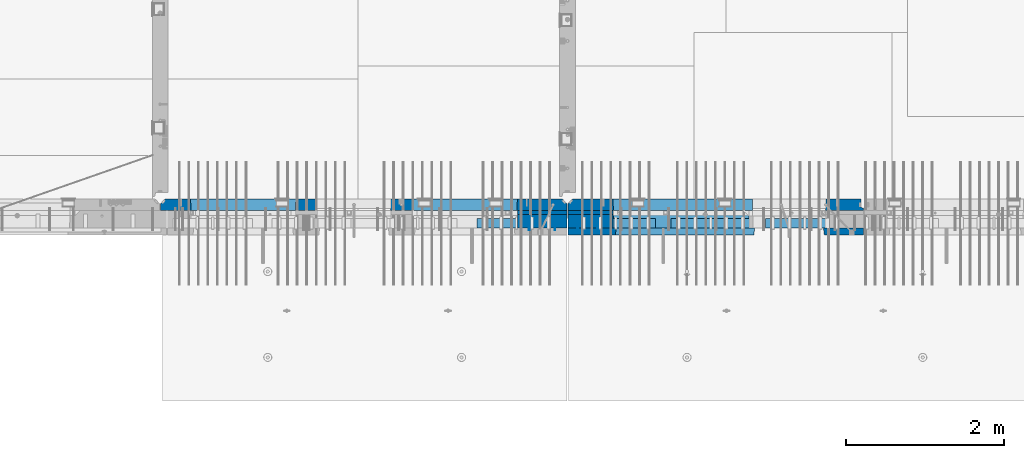
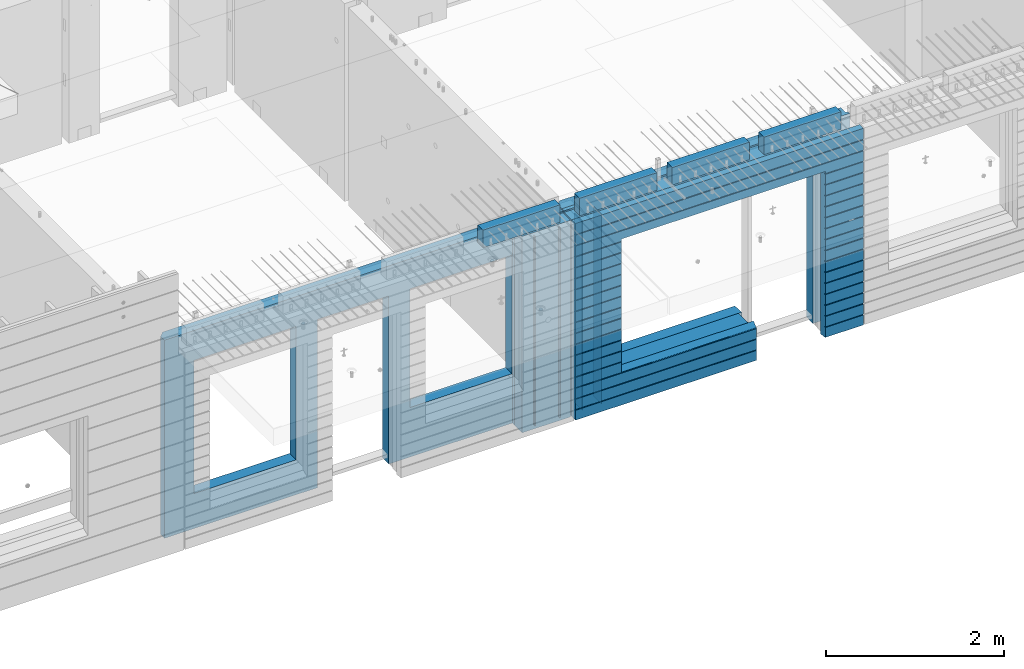
# One storey, part 197 of 309: 16 walls, 8 elements without a shape of their own.
"""IFC2X3 building model written with IfcOpenShell, lengths in millimetres."""

from ifc_helpers import new_model, si_unit, frame, origin_with_axes, place, context, subcontext, project, spatial, faceted_brep, material, type_object, element, aggregate, save


model = new_model("IFC2X3")

# Units and contexts
model_context = context("Model", 3, precision=1e-05, world=origin_with_axes())
body_context = subcontext(model_context, "Body", "Model", "MODEL_VIEW")
ifc_project = project(units=[si_unit("LENGTHUNIT", "METRE", prefix="MILLI"), si_unit("AREAUNIT", "SQUARE_METRE"), si_unit("VOLUMEUNIT", "CUBIC_METRE"), si_unit("MASSUNIT", "GRAM", prefix="KILO"), si_unit("TIMEUNIT", "SECOND"), si_unit("PLANEANGLEUNIT", "RADIAN"), si_unit("SOLIDANGLEUNIT", "STERADIAN"), si_unit("THERMODYNAMICTEMPERATUREUNIT", "DEGREE_CELSIUS"), si_unit("LUMINOUSINTENSITYUNIT", "LUMEN")], contexts=[model_context])

# Site, building, storey
site_placement = place(None, origin_with_axes())
site = spatial("IfcSite", under=ifc_project, at=site_placement, CompositionType="ELEMENT")
building_placement = place(site_placement, origin_with_axes())
building = spatial("IfcBuilding", under=site, at=building_placement, CompositionType="ELEMENT")
storey_placement = place(building_placement, origin_with_axes())
storey = spatial("IfcBuildingStorey", under=building, at=storey_placement, Name="7", CompositionType="ELEMENT", Elevation=0.0)

# Assembly, walls
assembly_1_placement = place(storey_placement, origin_with_axes())
assembly_1 = element("IfcElementAssembly", 1, at=assembly_1_placement, inside=storey, AssemblyPlace="NOTDEFINED", PredefinedType="REINFORCEMENT_UNIT")
ifc_material_1 = material(Name="Undefined")
wall_type_1 = type_object("IfcWallType", PredefinedType="NOTDEFINED")
wall_1_placement = place(assembly_1_placement, frame((21325.0, 7780.0, 101115.0), z_axis=(0.0, 0.0, 1.0), x_axis=(0.0, -1.0, 0.0)))
wall_1 = element("IfcWall", 2, at=wall_1_placement, type_object=wall_type_1, material=ifc_material_1, Name="(PD)", context=body_context, shape_type="Brep", body=[
    faceted_brep([(0.0, 5.0, -1300.0), (0.0, 5.0, 1300.0), (180.0, 5.0, 1300.0), (180.0, 5.0, -1300.0), (0.0, -5.0, 1300.0), (180.0, -5.0, 1300.0), (0.0, -5.0, -1300.0), (180.0, -5.0, -1300.0)], [[[0, 1, 2, 3]], [[1, 4, 5, 2]], [[4, 6, 7, 5]], [[6, 0, 3, 7]], [[5, 7, 3, 2]], [[6, 4, 1, 0]]]),
])
wall_2_placement = place(assembly_1_placement, frame((21650.0, 7780.0, 101115.0), z_axis=(0.0, 0.0, 1.0), x_axis=(0.0, -1.0, 0.0)))
wall_2 = element("IfcWall", 3, at=wall_2_placement, type_object=wall_type_1, material=ifc_material_1, Name="(PD)", context=body_context, shape_type="Brep", body=[
    faceted_brep([(0.0, 5.0, -1300.0), (0.0, 5.0, 1300.0), (180.0, 5.0, 1300.0), (180.0, 5.0, -1300.0), (0.0, -5.0, 1300.0), (180.0, -5.0, 1300.0), (0.0, -5.0, -1300.0), (180.0, -5.0, -1300.0)], [[[0, 1, 2, 3]], [[1, 4, 5, 2]], [[4, 6, 7, 5]], [[6, 0, 3, 7]], [[5, 7, 3, 2]], [[6, 4, 1, 0]]]),
])

assembly_2_placement = place(storey_placement, origin_with_axes())
assembly_2 = element("IfcElementAssembly", 4, at=assembly_2_placement, inside=storey, AssemblyPlace="NOTDEFINED", PredefinedType="REINFORCEMENT_UNIT")
wall_3_placement = place(assembly_2_placement, frame((22190.0, 7780.0, 101115.0), z_axis=(0.0, 0.0, 1.0), x_axis=(0.0, -1.0, 0.0)))
wall_3 = element("IfcWall", 5, at=wall_3_placement, type_object=wall_type_1, material=ifc_material_1, Name="(PD)", context=body_context, shape_type="Brep", body=[
    faceted_brep([(0.0, 5.0, -1300.0), (0.0, 5.0, 1300.0), (180.0, 5.0, 1300.0), (180.0, 5.0, -1300.0), (0.0, -5.0, 1300.0), (180.0, -5.0, 1300.0), (0.0, -5.0, -1300.0), (180.0, -5.0, -1300.0)], [[[0, 1, 2, 3]], [[1, 4, 5, 2]], [[4, 6, 7, 5]], [[6, 0, 3, 7]], [[5, 7, 3, 2]], [[6, 4, 1, 0]]]),
])
wall_4_placement = place(assembly_2_placement, frame((21940.0, 7780.0, 101115.0), z_axis=(0.0, 0.0, 1.0), x_axis=(0.0, -1.0, 0.0)))
wall_4 = element("IfcWall", 6, at=wall_4_placement, type_object=wall_type_1, material=ifc_material_1, Name="(PD)", context=body_context, shape_type="Brep", body=[
    faceted_brep([(0.0, 5.0, -1300.0), (0.0, 5.0, 1300.0), (180.0, 5.0, 1300.0), (180.0, 5.0, -1300.0), (0.0, -5.0, 1300.0), (180.0, -5.0, 1300.0), (0.0, -5.0, -1300.0), (180.0, -5.0, -1300.0)], [[[0, 1, 2, 3]], [[1, 4, 5, 2]], [[4, 6, 7, 5]], [[6, 0, 3, 7]], [[5, 7, 3, 2]], [[6, 4, 1, 0]]]),
])

# Assemblies, walls
assembly_3_placement = place(storey_placement, origin_with_axes())
assembly_3 = element("IfcElementAssembly", 7, at=assembly_3_placement, inside=storey, AssemblyPlace="NOTDEFINED", PredefinedType="REINFORCEMENT_UNIT")
assembly_4_placement = place(assembly_3_placement, origin_with_axes())
assembly_4 = element("IfcElementAssembly", 8, at=assembly_4_placement, Name="Steel Assembly", AssemblyPlace="NOTDEFINED", PredefinedType="NOTDEFINED")
ifc_material_2 = material()
wall_type_2 = type_object("IfcWallType", PredefinedType="NOTDEFINED")
wall_5_placement = place(assembly_4_placement, frame((24309.9998568133, 7690.00021946163, 102590.0), z_axis=(0.0, 0.0, 1.0), x_axis=(1.0, 0.0, 0.0)))
wall_5 = element("IfcWall", 9, at=wall_5_placement, type_object=wall_type_2, material=ifc_material_2, context=body_context, shape_type="Brep", body=[
    faceted_brep([(0.0, 60.0, -120.0), (0.0, 60.0, 120.0), (1000.0, 60.0, 120.0), (1000.0, 60.0, -120.0), (0.0, -60.0, 120.0), (1000.0, -60.0, 120.0), (0.0, -60.0, -120.0), (1000.0, -60.0, -120.0)], [[[0, 1, 2, 3]], [[1, 4, 5, 2]], [[4, 6, 7, 5]], [[6, 0, 3, 7]], [[5, 7, 3, 2]], [[6, 4, 1, 0]]]),
])
aggregate(assembly_4, [wall_5])
assembly_5_placement = place(assembly_3_placement, origin_with_axes())
assembly_5 = element("IfcElementAssembly", 10, at=assembly_5_placement, Name="Steel Assembly", AssemblyPlace="NOTDEFINED", PredefinedType="NOTDEFINED")
wall_6_placement = place(assembly_5_placement, frame((23119.9998568133, 7690.00021946163, 102590.0), z_axis=(0.0, 0.0, 1.0), x_axis=(1.0, 0.0, 0.0)))
wall_6 = element("IfcWall", 11, at=wall_6_placement, type_object=wall_type_2, material=ifc_material_2, context=body_context, shape_type="Brep", body=[
    faceted_brep([(0.0, 60.0, -120.0), (0.0, 60.0, 120.0), (1000.0, 60.0, 120.0), (1000.0, 60.0, -120.0), (0.0, -60.0, 120.0), (1000.0, -60.0, 120.0), (0.0, -60.0, -120.0), (1000.0, -60.0, -120.0)], [[[0, 1, 2, 3]], [[1, 4, 5, 2]], [[4, 6, 7, 5]], [[6, 0, 3, 7]], [[5, 7, 3, 2]], [[6, 4, 1, 0]]]),
])
aggregate(assembly_5, [wall_6])
assembly_6_placement = place(assembly_3_placement, origin_with_axes())
assembly_6 = element("IfcElementAssembly", 12, at=assembly_6_placement, Name="Steel Assembly", AssemblyPlace="NOTDEFINED", PredefinedType="NOTDEFINED")
aggregate(assembly_3, [assembly_4, assembly_5, assembly_6])
wall_7_placement = place(assembly_6_placement, frame((21919.9998568133, 7690.00021946163, 102590.0), z_axis=(0.0, 0.0, 1.0), x_axis=(1.0, 0.0, 0.0)))
wall_7 = element("IfcWall", 13, at=wall_7_placement, type_object=wall_type_2, material=ifc_material_2, context=body_context, shape_type="Brep", body=[
    faceted_brep([(0.0, 60.0, -120.0), (0.0, 60.0, 120.0), (1000.0, 60.0, 120.0), (1000.0, 60.0, -120.0), (0.0, -60.0, 120.0), (1000.0, -60.0, 120.0), (0.0, -60.0, -120.0), (1000.0, -60.0, -120.0)], [[[0, 1, 2, 3]], [[1, 4, 5, 2]], [[4, 6, 7, 5]], [[6, 0, 3, 7]], [[5, 7, 3, 2]], [[6, 4, 1, 0]]]),
])
aggregate(assembly_6, [wall_7])

# Assemblies, wall
assembly_7_placement = place(storey_placement, origin_with_axes())
assembly_7 = element("IfcElementAssembly", 14, at=assembly_7_placement, inside=storey, AssemblyPlace="NOTDEFINED", PredefinedType="REINFORCEMENT_UNIT")
assembly_8_placement = place(assembly_7_placement, origin_with_axes())
assembly_8 = element("IfcElementAssembly", 15, at=assembly_8_placement, Name="Steel Assembly", AssemblyPlace="NOTDEFINED", PredefinedType="NOTDEFINED")
aggregate(assembly_7, [assembly_8])
wall_8_placement = place(assembly_8_placement, frame((20664.9998568133, 7690.00021946163, 102590.0), z_axis=(0.0, 0.0, 1.0), x_axis=(1.0, 0.0, 0.0)))
wall_8 = element("IfcWall", 16, at=wall_8_placement, type_object=wall_type_2, material=ifc_material_2, context=body_context, shape_type="Brep", body=[
    faceted_brep([(0.0, 60.0, -120.0), (0.0, 60.0, 120.0), (1000.0, 60.0, 120.0), (1000.0, 60.0, -120.0), (0.0, -60.0, 120.0), (1000.0, -60.0, 120.0), (0.0, -60.0, -120.0), (1000.0, -60.0, -120.0)], [[[0, 1, 2, 3]], [[1, 4, 5, 2]], [[4, 6, 7, 5]], [[6, 0, 3, 7]], [[5, 7, 3, 2]], [[6, 4, 1, 0]]]),
])
aggregate(assembly_8, [wall_8])

# Wall
ifc_material_3 = material(Name="CONCRETE/C35/45")
wall_type_3 = type_object("IfcWallType", PredefinedType="NOTDEFINED")
wall_9_placement = place(assembly_1_placement, frame((21810.0, 7925.0, 101112.5), z_axis=(0.0, 0.0, 1.0), x_axis=(-1.0, 3.00000001838171e-08, 0.0)))
wall_9 = element("IfcWall", 17, at=wall_9_placement, type_object=wall_type_3, material=ifc_material_3, context=body_context, shape_type="Brep", body=[
    faceted_brep([(5145.0, 75.0, -1357.5), (5145.0, -15.0, -1357.5), (5085.0, -75.0, -1357.5), (3165.00051719707, -75.0, -1357.5), (3161.15436335092, 75.0, -1357.5), (5085.0, -75.0, 1357.5), (5145.0, -15.0, 1357.5), (5145.0, 75.0, 1357.5), (10.0, 75.0, 1357.5), (10.0, -15.0, 1357.5), (70.0, -75.0, 1357.5), (10.0, -15.0, -1357.5), (70.0, -75.0, -1357.5), (10.0, 75.0, -1357.5), (2238.84667104322, 75.0, -1357.5), (2235.00051719707, -75.0, -1357.5), (2238.84667104322, 75.0, 948.653846153844), (2235.00051719707, -75.0, 952.5), (635.00013572734, -75.0, -682.5), (639.054189781393, 75.0, -678.445945945947), (639.054189781393, 75.0, 948.445945945947), (635.00013572734, -75.0, 952.5), (1965.00013572734, -75.0, -682.5), (1960.94608167329, 75.0, -678.445945945947), (1965.00013572734, -75.0, 952.5), (1960.94608167329, 75.0, 948.445945945947), (4764.99937278789, -75.0, -882.5), (4760.94531873383, 75.0, -878.445945945947), (3439.05342684194, 75.0, -878.445945945947), (3434.99937278789, -75.0, -882.5), (3165.00051719707, -75.0, 952.5), (3434.99937278789, -75.0, 952.5), (4764.99937278789, -75.0, 952.5), (4760.94531873383, 75.0, 948.445945945947), (3439.05342684194, 75.0, 948.445945945947), (3161.15436335092, 75.0, 948.653846153844)], [[[0, 1, 2, 3, 4]], [[5, 2, 1, 6]], [[0, 7, 6, 1]], [[5, 6, 7, 8, 9, 10]], [[9, 11, 12, 10]], [[8, 13, 11, 9]], [[12, 11, 13, 14, 15]], [[15, 14, 16, 17]], [[18, 19, 20, 21]], [[22, 23, 19, 18]], [[23, 22, 24, 25]], [[21, 20, 25, 24]], [[26, 27, 28, 29]], [[3, 2, 5, 10, 12, 15, 17, 30], [26, 29, 31, 32], [22, 18, 21, 24]], [[27, 26, 32, 33]], [[31, 34, 33, 32]], [[29, 28, 34, 31]], [[13, 8, 7, 0, 4, 35, 16, 14], [27, 33, 34, 28], [23, 25, 20, 19]], [[17, 16, 35, 30]], [[4, 3, 30, 35]]]),
])

wall_10_placement = place(assembly_2_placement, frame((25550.0, 7925.0, 101112.5), z_axis=(0.0, 0.0, 1.0), x_axis=(-1.0, 3.00000001838171e-08, 0.0)))
wall_10 = element("IfcWall", 18, at=wall_10_placement, type_object=wall_type_3, material=ifc_material_3, context=body_context, shape_type="Brep", body=[
    faceted_brep([(0.0, 75.0, 1357.5), (0.0, 75.0, -1357.5), (0.0, 45.0, -1357.5), (0.0, 45.0, 1357.5), (475.000517197066, -75.0, -1357.5), (478.846671043222, 75.0, -1357.5), (478.846671043219, 75.0, 948.653846153844), (475.000517197066, -75.0, 952.5), (32.5, -75.0, -1357.5), (32.5, 32.0, -1357.5), (32.5, -75.0, 1357.5), (32.5, 32.0, 1357.5), (3675.0, -75.0, 1357.5), (3735.0, -15.0, 1357.5), (3735.0, 75.0, 1357.5), (3735.0, 75.0, -1357.5), (3735.0, -15.0, -1357.5), (3675.0, -75.0, -1357.5), (1405.00051719707, -75.0, -1357.5), (1401.15436335091, 75.0, -1357.5), (1405.00051719707, -75.0, -882.5), (1401.15436335091, 75.0, -878.445945945947), (1334.05403802673, 75.0, 948.653846153844), (3160.9460816706, 75.0, -878.445945945947), (3160.9460816706, 75.0, 948.445945945947), (1401.15436335091, 75.0, 948.653846153844), (1330.00013572465, -75.0, 952.5), (1405.00051719707, -75.0, 952.5), (3165.00013572465, -75.0, -882.5), (3165.00013572465, -75.0, 952.5)], [[[0, 1, 2, 3]], [[4, 5, 6, 7]], [[8, 9, 2, 1, 5, 4]], [[10, 11, 9, 8]], [[3, 2, 9, 11]], [[10, 12, 13, 14, 0, 3, 11]], [[15, 14, 13, 16]], [[12, 17, 16, 13]], [[15, 16, 17, 18, 19]], [[19, 18, 20, 21]], [[22, 6, 5, 1, 0, 14, 15, 19, 21, 23, 24, 25]], [[26, 7, 6, 22, 25, 27]], [[28, 20, 18, 17, 12, 10, 8, 4, 7, 26, 27, 29]], [[25, 24, 29, 27]], [[23, 28, 29, 24]], [[21, 20, 28, 23]]]),
])

wall_type_4 = type_object("IfcWallType", PredefinedType="NOTDEFINED")
wall_11_placement = place(assembly_1_placement, frame((21800.0000381475, 7825.0, 101112.5), z_axis=(0.0, 0.0, 1.0), x_axis=(-1.0, 3.00000001838171e-08, 0.0)))
wall_11 = element("IfcWall", 19, at=wall_11_placement, type_object=wall_type_4, material=ifc_material_3, context=body_context, shape_type="Brep", body=[
    faceted_brep([(0.0, 25.0, -1357.5), (0.0, 25.0, 1357.5), (625.001908754726, 25.0, 1357.5), (625.001908754726, 25.0, -1357.5), (0.0, -25.0, 1357.5), (625.001908754726, -25.0, 1357.5), (0.0, -25.0, -1357.5), (625.001908754726, -25.0, -1357.5)], [[[0, 1, 2, 3]], [[1, 4, 5, 2]], [[4, 6, 7, 5]], [[6, 0, 3, 7]], [[5, 7, 3, 2]], [[6, 4, 1, 0]]]),
])

wall_12_placement = place(assembly_2_placement, frame((22385.0000381475, 7825.00011629906, 101112.5), z_axis=(0.0, 0.0, 1.0), x_axis=(-1.0, 3.00000001838171e-08, 0.0)))
wall_12 = element("IfcWall", 20, at=wall_12_placement, type_object=wall_type_4, material=ifc_material_3, context=body_context, shape_type="Brep", body=[
    faceted_brep([(0.0, 25.0, -1357.5), (0.0, 25.0, 1357.5), (570.001908754726, 25.0, 1357.5), (570.001908754726, 25.0, -1357.5), (0.0, -25.0, 1357.5), (570.001908754726, -25.0, 1357.5), (0.0, -25.0, -1357.5), (570.001908754726, -25.0, -1357.5)], [[[0, 1, 2, 3]], [[1, 4, 5, 2]], [[4, 6, 7, 5]], [[6, 0, 3, 7]], [[5, 7, 3, 2]], [[6, 4, 1, 0]]]),
])

ifc_material_4 = material(Name="SPU")
wall_type_5 = type_object("IfcWallType", PredefinedType="NOTDEFINED")
wall_13_placement = place(assembly_1_placement, frame((21800.0000381475, 7715.0, 101102.5), z_axis=(0.0, 0.0, 1.0), x_axis=(-1.0, 3.00000001838171e-08, 0.0)))
wall_13 = element("IfcWall", 21, at=wall_13_placement, type_object=wall_type_5, material=ifc_material_4, context=body_context, shape_type="Brep", body=[
    faceted_brep([(0.0, 85.0, -1347.5), (0.0, 85.0, 1347.5), (625.001908754726, 85.0, 1347.5), (625.001908754726, 85.0, -1347.5), (0.0, -85.0, 1347.5), (625.001908754726, -85.0, 1347.5), (0.0, -85.0, -1347.5), (625.001908754726, -85.0, -1347.5)], [[[0, 1, 2, 3]], [[1, 4, 5, 2]], [[4, 6, 7, 5]], [[6, 0, 3, 7]], [[5, 7, 3, 2]], [[6, 4, 1, 0]]]),
])

aggregate(assembly_1, [wall_13, wall_11, wall_1, wall_2, wall_9])

wall_14_placement = place(assembly_2_placement, frame((22385.0000381475, 7715.00011629906, 101102.5), z_axis=(0.0, 0.0, 1.0), x_axis=(-1.0, 3.00000001838171e-08, 0.0)))
wall_14 = element("IfcWall", 22, at=wall_14_placement, type_object=wall_type_5, material=ifc_material_4, context=body_context, shape_type="Brep", body=[
    faceted_brep([(0.0, 85.0, -1347.5), (0.0, 85.0, 1347.5), (570.001908754726, 85.0, 1347.5), (570.001908754726, 85.0, -1347.5), (0.0, -85.0, 1347.5), (570.001908754726, -85.0, 1347.5), (0.0, -85.0, -1347.5), (570.001908754726, -85.0, -1347.5)], [[[0, 1, 2, 3]], [[1, 4, 5, 2]], [[4, 6, 7, 5]], [[6, 0, 3, 7]], [[5, 7, 3, 2]], [[6, 4, 1, 0]]]),
])

ifc_material_5 = material(Name="CONCRETE/C30/37")
wall_type_6 = type_object("IfcWallType", PredefinedType="NOTDEFINED")
wall_15_placement = place(assembly_2_placement, frame((25550.0, 7587.5, 101102.5), z_axis=(0.0, 0.0, 1.0), x_axis=(-1.0, 3.00000001838171e-08, 0.0)))
wall_15 = element("IfcWall", 23, at=wall_15_placement, type_object=wall_type_6, material=ifc_material_5, context=body_context, shape_type="Brep", body=[
    faceted_brep([(3135.00013572465, 42.5, -912.000000055254), (3135.00013572465, 42.5, -912.5), (3134.8486205936, 41.2121213860491, -911.742424344731), (3735.0, 32.4999991126861, -1049.99999959956), (3735.0, 32.4999992506973, -1060.00000000076), (1383.82179161871, 32.4999992506973, -1060.00000000076), (1383.82179160247, 32.4999991126861, -1049.99999959956), (3735.0, 42.5, -1062.00000005522), (1384.99845837354, 42.5, -1062.00000005522), (3735.0, 42.5, -1198.00000011075), (1384.99845837354, 42.5, -1198.00000011075), (3735.0, 32.4999991121604, -1199.99999959957), (1383.8217916024, 32.4999991121604, -1199.99999959957), (3735.0, 32.4999992501671, -1210.00000000079), (1383.82179161864, 32.4999992501671, -1210.00000000079), (3735.0, 42.5, -1212.00000005524), (1384.99845837354, 42.5, -1212.00000005524), (3735.0, 42.5, -1347.5), (1384.99845837354, 42.5, -1347.5), (3735.0, -42.5, -1347.5), (1374.99679170687, -42.5, -1347.5), (3.63797880709171e-12, 32.4999992499725, 1039.99999999921), (3735.0, 32.4999992499725, 1039.99999999921), (3735.0, 42.5, 1037.99999994476), (0.0, 42.5, 1037.99999994476), (3.63797880709171e-12, 32.4999991119639, 1050.00000040043), (3735.0, 32.4999991119639, 1050.00000040043), (0.0, 42.5, 1051.99999988925), (3735.0, 42.5, 1051.99999988925), (0.0, 42.5, 1187.99999994476), (3735.0, 42.5, 1187.99999994476), (-3.63797880709171e-12, 32.499999249967, 1189.99999999923), (3735.0, 32.499999249967, 1189.99999999923), (-3.63797880709171e-12, 32.4999991119576, 1200.00000040043), (3735.0, 32.4999991119576, 1200.00000040043), (0.0, 42.5, 1201.99999988925), (3735.0, 42.5, 1201.99999988925), (0.0, 42.5, 1347.5), (3735.0, 42.5, 1347.5), (0.0, -42.5, 1347.5), (3735.0, -42.5, 1347.5), (3125.00013572465, -42.5, 927.5), (3125.00013572465, -42.5, -862.5), (1374.99679170687, -42.5, -862.5), (0.0, -42.5, -1347.5), (505.000125040202, -42.5, -1347.5), (505.000125040206, -42.5, 927.5), (505.000125040206, -42.5, 932.502857142856), (1370.00013572465, -42.5, 932.502857142856), (1374.99679170687, -42.5, 932.5), (3125.00013572465, -42.5, 932.5), (0.0, 42.5, -1347.5), (494.998458373539, 42.5, -1347.5), (0.0, 42.5, -1212.00000005524), (494.998458373539, 42.5, -1212.00000005524), (0.0, 32.4999992501671, -1210.00000000079), (496.175125128437, 32.4999992501671, -1210.00000000079), (0.0, 32.4999991121604, -1199.99999959957), (496.175125144673, 32.4999991121604, -1199.99999959957), (0.0, 42.5, -1198.00000011075), (494.998458373539, 42.5, -1198.00000011075), (0.0, 42.5, -1062.00000005522), (494.998458373539, 42.5, -1062.00000005522), (0.0, 32.4999992506973, -1060.00000000076), (496.175125128375, 32.4999992506973, -1060.00000000076), (0.0, 32.4999991126861, -1049.99999959956), (496.175125144611, 32.4999991126861, -1049.99999959956), (0.0, 42.5, -1048.00000011074), (494.998458373539, 42.5, -1048.00000011074), (0.0, 42.5, -912.000000055254), (494.998458373539, 42.5, -912.000000055254), (0.0, 32.4999992512376, -910.000000000786), (496.175125128309, 32.4999992512376, -910.000000000786), (0.0, 32.499999113239, -899.99999959959), (496.175125144546, 32.499999113239, -899.99999959959), (0.0, 42.5, -898.000000110769), (494.998458373539, 42.5, -898.000000110769), (0.0, 42.5, -762.000000055225), (494.998458373539, 42.5, -762.000000055225), (0.0, 32.4999992517696, -760.000000000757), (496.175125128244, 32.4999992517696, -760.000000000757), (0.0, 32.4999991137702, -749.99999959956), (496.175125144484, 32.4999991137702, -749.99999959956), (0.0, 42.5, -748.00000011074), (494.998458373539, 42.5, -748.00000011074), (0.0, 42.5, -612.000000055239), (494.998458373539, 42.5, -612.000000055239), (0.0, 32.4999992522971, -610.000000000771), (496.175125128182, 32.4999992522971, -610.000000000771), (0.0, 32.4999991143004, -599.99999959956), (496.175125144422, 32.4999991143004, -599.99999959956), (0.0, 42.5, -598.000000110755), (494.998458373539, 42.5, -598.000000110755), (0.0, 42.5, -462.000000055239), (494.998458373539, 42.5, -462.000000055239), (0.0, 32.4999992528365, -460.000000000771), (496.17512512812, 32.4999992528365, -460.000000000771), (0.0, 32.4999991148252, -449.999999599575), (496.17512514436, 32.4999991148252, -449.999999599575), (0.0, 42.5, -448.000000110755), (494.998458373539, 42.5, -448.000000110755), (0.0, 42.5, -312.000000055254), (494.998458373539, 42.5, -312.000000055254), (0.0, 32.4999992533649, -310.000000000786), (496.175125128058, 32.4999992533649, -310.000000000786), (0.0, 32.4999991153618, -299.99999959959), (496.175125144298, 32.4999991153618, -299.99999959959), (0.0, 42.5, -298.000000110769), (494.998458373539, 42.5, -298.000000110769), (0.0, 42.5, -162.000000055239), (494.998458373539, 42.5, -162.000000055239), (0.0, 32.4999992538978, -160.000000000757), (496.175125127997, 32.4999992538978, -160.000000000757), (0.0, 32.4999991158993, -149.99999959956), (496.175125144237, 32.4999991158993, -149.99999959956), (0.0, 42.5, -148.000000110755), (494.998458373539, 42.5, -148.000000110755), (0.0, 42.5, -12.0000000552391), (494.998458373539, 42.5, -12.0000000552391), (0.0, 32.4999992538942, -10.0000000007858), (496.175125127997, 32.4999992538942, -10.0000000007858), (3.63797880709171e-12, 32.4999992499852, 889.999999999229), (3.63797880709171e-12, 32.4999991119857, 900.000000400425), (496.175125144691, 32.4999991119857, 900.000000400425), (496.175125128459, 32.4999992499852, 889.999999999229), (0.0, 42.5, 887.999999944761), (494.998458373539, 42.5, 887.999999944761), (0.0, 42.5, 751.999999889245), (494.998458373539, 42.5, 751.999999889245), (0.0, 32.4999991120039, 750.00000040044), (496.175125144691, 32.4999991120039, 750.00000040044), (0.0, 32.4999992499997, 739.999999999229), (496.175125128455, 32.4999992499997, 739.999999999229), (0.0, 42.5, 737.999999944761), (494.998458373539, 42.5, 737.999999944761), (0.0, 42.5, 601.99999988926), (494.998458373539, 42.5, 601.99999988926), (0.0, 32.4999991120094, 600.00000040044), (496.175125144691, 32.4999991120094, 600.00000040044), (0.0, 32.499999250017, 589.999999999229), (496.175125128455, 32.499999250017, 589.999999999229), (0.0, 42.5, 587.999999944775), (494.998458373539, 42.5, 587.999999944775), (0.0, 42.5, 451.999999889231), (494.998458373539, 42.5, 451.999999889231), (0.0, 32.4999991120258, 450.000000400411), (496.175125144688, 32.4999991120258, 450.000000400411), (0.0, 32.4999992500289, 439.999999999214), (496.175125128451, 32.4999992500289, 439.999999999214), (0.0, 42.5, 437.999999944746), (494.998458373539, 42.5, 437.999999944746), (0.0, 42.5, 301.999999889245), (494.998458373539, 42.5, 301.999999889245), (-3.63797880709171e-12, 32.4999991120458, 300.00000040044), (496.175125144688, 32.4999991120458, 300.00000040044), (-3.63797880709171e-12, 32.4999992500416, 289.999999999229), (496.175125128451, 32.4999992500416, 289.999999999229), (0.0, 42.5, 287.999999944761), (494.998458373539, 42.5, 287.999999944761), (0.0, 42.5, 151.99999988926), (494.998458373539, 42.5, 151.99999988926), (0.0, 32.4999991120549, 150.00000040044), (496.175125144684, 32.4999991120549, 150.00000040044), (0.0, 32.4999992500552, 139.999999999229), (496.175125128448, 32.4999992500552, 139.999999999229), (0.0, 42.5, 137.999999944775), (494.998458373539, 42.5, 137.999999944775), (0.0, 42.5, 1.99999988924537), (494.998458373539, 42.5, 1.99999988924537), (0.0, 32.4999991158911, 4.00425051338971e-07), (496.175125144237, 32.4999991158911, 4.00425051338971e-07), (0.0, 42.5, 901.999999889245), (494.998458373539, 42.5, 901.999999889245), (494.998458373539, 42.5, 927.5), (505.000517197066, 42.5, 927.5), (1360.00013572465, 42.5, 927.5), (1370.00013572465, 42.5, 927.5), (1375.00051719707, 42.5, 927.5), (1384.99845837354, 42.5, 927.5), (3125.00013572465, 42.5, 927.5), (3135.00013572465, 42.5, 927.5), (3735.0, 42.5, 901.999999889245), (3135.00013572465, 42.5, 901.999999889245), (3735.0, 32.4999991119857, 900.000000400425), (3133.82366503195, 32.4999991119857, 900.000000400425), (3735.0, 32.4999992499852, 889.999999999229), (3133.82366504818, 32.4999992499852, 889.999999999229), (3735.0, 42.5, 887.999999944761), (3135.00013572465, 42.5, 887.999999944761), (3735.0, 42.5, 751.999999889245), (3135.00013572465, 42.5, 751.999999889245), (3735.0, 32.4999991120039, 750.00000040044), (3133.82366503195, 32.4999991120039, 750.00000040044), (3735.0, 32.4999992499997, 739.999999999229), (3133.82366504818, 32.4999992499997, 739.999999999229), (3735.0, 42.5, 737.999999944761), (3135.00013572465, 42.5, 737.999999944761), (3735.0, 42.5, 601.99999988926), (3135.00013572465, 42.5, 601.99999988926), (3735.0, 32.4999991120094, 600.00000040044), (3133.82366503195, 32.4999991120094, 600.00000040044), (3735.0, 32.499999250017, 589.999999999229), (3133.82366504818, 32.499999250017, 589.999999999229), (3735.0, 42.5, 587.999999944775), (3135.00013572465, 42.5, 587.999999944775), (3735.0, 42.5, 451.999999889231), (3135.00013572465, 42.5, 451.999999889231), (3735.0, 32.4999991120258, 450.000000400411), (3133.82366503195, 32.4999991120258, 450.000000400411), (3735.0, 32.4999992500289, 439.999999999214), (3133.82366504818, 32.4999992500289, 439.999999999214), (3735.0, 42.5, 437.999999944746), (3135.00013572465, 42.5, 437.999999944746), (3735.0, 42.5, 301.999999889245), (3135.00013572465, 42.5, 301.999999889245), (3735.0, 32.4999991120458, 300.00000040044), (3133.82366503195, 32.4999991120458, 300.00000040044), (3735.0, 32.4999992500416, 289.999999999229), (3133.82366504819, 32.4999992500416, 289.999999999229), (3735.0, 42.5, 287.999999944761), (3135.00013572465, 42.5, 287.999999944761), (3735.0, 42.5, 151.99999988926), (3135.00013572465, 42.5, 151.99999988926), (3735.0, 32.4999991120549, 150.00000040044), (3133.82366503195, 32.4999991120549, 150.00000040044), (3735.0, 32.4999992500552, 139.999999999229), (3133.82366504819, 32.4999992500552, 139.999999999229), (3735.0, 42.5, 137.999999944775), (3135.00013572465, 42.5, 137.999999944775), (3735.0, 42.5, 1.99999988924537), (3135.00013572465, 42.5, 1.99999988924537), (3735.0, 32.4999991158911, 4.00425051338971e-07), (3735.0, 32.4999992538942, -10.0000000007858), (3133.82366504864, 32.4999992538942, -10.0000000007858), (3133.8236650324, 32.4999991158911, 4.00425051338971e-07), (3735.0, 42.5, -12.0000000552391), (3135.00013572465, 42.5, -12.0000000552391), (3735.0, 42.5, -148.000000110755), (3135.00013572465, 42.5, -148.000000110755), (3735.0, 32.4999991158993, -149.99999959956), (3133.8236650324, 32.4999991158993, -149.99999959956), (3735.0, 32.4999992538978, -160.000000000757), (3133.82366504864, 32.4999992538978, -160.000000000757), (3735.0, 42.5, -162.000000055239), (3135.00013572465, 42.5, -162.000000055239), (3735.0, 42.5, -298.000000110769), (3135.00013572465, 42.5, -298.000000110769), (3735.0, 32.4999991153618, -299.99999959959), (3133.82366503234, 32.4999991153618, -299.99999959959), (3735.0, 32.4999992533649, -310.000000000786), (3133.82366504858, 32.4999992533649, -310.000000000786), (3735.0, 42.5, -312.000000055254), (3135.00013572465, 42.5, -312.000000055254), (3735.0, 42.5, -448.000000110755), (3135.00013572465, 42.5, -448.000000110755), (3735.0, 32.4999991148252, -449.999999599575), (3133.82366503228, 32.4999991148252, -449.999999599575), (3735.0, 32.4999992528365, -460.000000000771), (3133.82366504852, 32.4999992528365, -460.000000000771), (3735.0, 42.5, -462.000000055239), (3135.00013572465, 42.5, -462.000000055239), (3735.0, 42.5, -598.000000110755), (3135.00013572465, 42.5, -598.000000110755), (3735.0, 32.4999991143004, -599.99999959956), (3133.82366503222, 32.4999991143004, -599.99999959956), (3735.0, 32.4999992522971, -610.000000000771), (3133.82366504845, 32.4999992522971, -610.000000000771), (3735.0, 42.5, -612.000000055239), (3135.00013572465, 42.5, -612.000000055239), (3735.0, 42.5, -748.00000011074), (3135.00013572465, 42.5, -748.00000011074), (3735.0, 32.4999991137702, -749.99999959956), (3133.82366503216, 32.4999991137702, -749.99999959956), (3735.0, 32.4999992517696, -760.000000000757), (3133.82366504839, 32.4999992517696, -760.000000000757), (3735.0, 42.5, -762.000000055225), (3135.00013572465, 42.5, -762.000000055225), (3735.0, 42.5, -898.000000110769), (3135.00013572465, 42.5, -898.000000110769), (3735.0, 32.499999113239, -899.99999959959), (3133.82366503209, 32.499999113239, -899.99999959959), (3133.82366504284, 32.4999992045623, -906.617646590923), (3735.0, 42.5, -1048.00000011074), (3735.0, 42.5, -912.000000055254), (3735.0, 32.4999992512376, -910.000000000786), (1384.99845837354, 42.5, -1048.00000011074), (1384.99845837354, 42.5, -912.5), (1384.84691798997, 41.2121213860719, -911.742424344746), (1383.82179161877, 32.4999992512376, -910.000000000786), (1383.82179161327, 32.4999992045614, -906.617646590908)], [[[0, 1, 2]], [[3, 4, 5, 6]], [[4, 7, 8, 5]], [[7, 9, 10, 8]], [[9, 11, 12, 10]], [[11, 13, 14, 12]], [[13, 15, 16, 14]], [[15, 17, 18, 16]], [[17, 19, 20, 18]], [[21, 22, 23, 24]], [[25, 26, 22, 21]], [[27, 28, 26, 25]], [[28, 27, 29, 30]], [[31, 32, 30, 29]], [[33, 34, 32, 31]], [[35, 36, 34, 33]], [[37, 38, 36, 35]], [[37, 39, 40, 38]], [[41, 42, 43, 20, 19, 40, 39, 44, 45, 46, 47, 48, 49, 50]], [[44, 51, 52, 45]], [[51, 53, 54, 52]], [[53, 55, 56, 54]], [[55, 57, 58, 56]], [[57, 59, 60, 58]], [[59, 61, 62, 60]], [[61, 63, 64, 62]], [[63, 65, 66, 64]], [[65, 67, 68, 66]], [[67, 69, 70, 68]], [[69, 71, 72, 70]], [[71, 73, 74, 72]], [[73, 75, 76, 74]], [[75, 77, 78, 76]], [[77, 79, 80, 78]], [[79, 81, 82, 80]], [[81, 83, 84, 82]], [[83, 85, 86, 84]], [[85, 87, 88, 86]], [[87, 89, 90, 88]], [[89, 91, 92, 90]], [[91, 93, 94, 92]], [[93, 95, 96, 94]], [[95, 97, 98, 96]], [[97, 99, 100, 98]], [[99, 101, 102, 100]], [[101, 103, 104, 102]], [[103, 105, 106, 104]], [[105, 107, 108, 106]], [[107, 109, 110, 108]], [[109, 111, 112, 110]], [[111, 113, 114, 112]], [[113, 115, 116, 114]], [[115, 117, 118, 116]], [[117, 119, 120, 118]], [[121, 122, 123, 124]], [[125, 121, 124, 126]], [[127, 125, 126, 128]], [[129, 127, 128, 130]], [[131, 129, 130, 132]], [[133, 131, 132, 134]], [[135, 133, 134, 136]], [[137, 135, 136, 138]], [[139, 137, 138, 140]], [[141, 139, 140, 142]], [[143, 141, 142, 144]], [[145, 143, 144, 146]], [[147, 145, 146, 148]], [[149, 147, 148, 150]], [[151, 149, 150, 152]], [[153, 151, 152, 154]], [[155, 153, 154, 156]], [[157, 155, 156, 158]], [[159, 157, 158, 160]], [[161, 159, 160, 162]], [[163, 161, 162, 164]], [[165, 163, 164, 166]], [[167, 165, 166, 168]], [[169, 167, 168, 170]], [[119, 169, 170, 120]], [[117, 115, 113, 111, 109, 107, 105, 103, 101, 99, 97, 95, 93, 91, 89, 87, 85, 83, 81, 79, 77, 75, 73, 71, 69, 67, 65, 63, 61, 59, 57, 55, 53, 51, 44, 39, 37, 35, 33, 31, 29, 27, 25, 21, 24, 171, 122, 121, 125, 127, 129, 131, 133, 135, 137, 139, 141, 143, 145, 147, 149, 151, 153, 155, 157, 159, 161, 163, 165, 167, 169, 119]], [[122, 171, 172, 123]], [[173, 47, 46, 45, 52, 54, 56, 58, 60, 62, 64, 66, 68, 70, 72, 74, 76, 78, 80, 82, 84, 86, 88, 90, 92, 94, 96, 98, 100, 102, 104, 106, 108, 110, 112, 114, 116, 118, 120, 170, 168, 166, 164, 162, 160, 158, 156, 154, 152, 150, 148, 146, 144, 142, 140, 138, 136, 134, 132, 130, 128, 126, 124, 123, 172]], [[174, 175, 176, 177, 178, 49, 48, 47, 173]], [[49, 178, 179, 180, 50]], [[178, 177, 176, 175, 174, 173, 172, 171, 24, 23, 181, 182, 180, 179]], [[181, 183, 184, 182]], [[183, 185, 186, 184]], [[185, 187, 188, 186]], [[187, 189, 190, 188]], [[189, 191, 192, 190]], [[191, 193, 194, 192]], [[193, 195, 196, 194]], [[195, 197, 198, 196]], [[197, 199, 200, 198]], [[199, 201, 202, 200]], [[201, 203, 204, 202]], [[203, 205, 206, 204]], [[205, 207, 208, 206]], [[207, 209, 210, 208]], [[209, 211, 212, 210]], [[211, 213, 214, 212]], [[213, 215, 216, 214]], [[215, 217, 218, 216]], [[217, 219, 220, 218]], [[219, 221, 222, 220]], [[221, 223, 224, 222]], [[223, 225, 226, 224]], [[225, 227, 228, 226]], [[227, 229, 230, 228]], [[231, 232, 233, 234]], [[232, 235, 236, 233]], [[235, 237, 238, 236]], [[237, 239, 240, 238]], [[239, 241, 242, 240]], [[241, 243, 244, 242]], [[243, 245, 246, 244]], [[245, 247, 248, 246]], [[247, 249, 250, 248]], [[249, 251, 252, 250]], [[251, 253, 254, 252]], [[253, 255, 256, 254]], [[255, 257, 258, 256]], [[257, 259, 260, 258]], [[259, 261, 262, 260]], [[261, 263, 264, 262]], [[263, 265, 266, 264]], [[265, 267, 268, 266]], [[267, 269, 270, 268]], [[269, 271, 272, 270]], [[271, 273, 274, 272]], [[273, 275, 276, 274]], [[275, 277, 278, 276]], [[277, 279, 280, 278]], [[41, 50, 180, 182, 184, 186, 188, 190, 192, 194, 196, 198, 200, 202, 204, 206, 208, 210, 212, 214, 216, 218, 220, 222, 224, 226, 228, 230, 234, 233, 236, 238, 240, 242, 244, 246, 248, 250, 252, 254, 256, 258, 260, 262, 264, 266, 268, 270, 272, 274, 276, 278, 280, 281, 42]], [[229, 231, 234, 230]], [[227, 225, 223, 221, 219, 217, 215, 213, 211, 209, 207, 205, 203, 201, 199, 197, 195, 193, 191, 189, 187, 185, 183, 181, 23, 22, 26, 28, 30, 32, 34, 36, 38, 40, 19, 17, 15, 13, 11, 9, 7, 4, 3, 282, 283, 284, 279, 277, 275, 273, 271, 269, 267, 265, 263, 261, 259, 257, 255, 253, 251, 249, 247, 245, 243, 241, 239, 237, 235, 232, 231, 229]], [[0, 283, 282, 285, 286, 1]], [[287, 2, 1, 286]], [[288, 284, 283, 0, 2, 287]], [[280, 279, 284, 288, 289, 281]], [[43, 42, 281, 289]], [[288, 287, 286, 285, 6, 5, 8, 10, 12, 14, 16, 18, 20, 43, 289]], [[282, 3, 6, 285]]]),
])

ifc_material_6 = material(Name="COS5gt")
wall_type_7 = type_object("IfcWallType", PredefinedType="NOTDEFINED")
wall_16_placement = place(assembly_2_placement, frame((25075.0, 7740.0, 101102.5), z_axis=(0.0, 0.0, 1.0), x_axis=(-1.0, 3.00000001838171e-08, 0.0)))
wall_16 = element("IfcWall", 24, at=wall_16_placement, type_object=wall_type_7, material=ifc_material_6, context=body_context, shape_type="Brep", body=[
    faceted_brep([(2690.0, 90.0, -1297.5), (2690.0, 90.0, -1347.5), (970.000517197066, 90.0, -1347.5), (970.000517197066, 90.0, -1297.5), (2690.0, 110.0, -1297.5), (970.000517197066, 110.0, -1297.5), (2690.0, 110.0, 1347.5), (2690.0, -110.0, 1347.5), (2690.0, -110.0, -1347.5), (0.0, 110.0, 1347.5), (0.0, -110.0, 1347.5), (0.0, 110.0, 1002.5), (0.0, -110.0, 1002.5), (970.000517197066, 110.0, 1002.5), (970.000517197066, -110.0, 1002.5), (970.000517197066, 110.0, 952.5), (970.000517197066, -110.0, 958.445945945947), (2685.9460816706, -110.000000000001, -868.445945945947), (970.000517197066, -110.0, -868.445945945947), (970.000517197066, -110.0, -1347.5), (2685.9460816706, -110.0, 958.445945945947), (2680.00013572465, 110.0, -857.5), (2680.00013572465, 110.0, -862.5), (2680.00013572465, 110.0, 952.5), (970.000517197066, 110.0, -862.5), (2650.00013572465, 110.0, -862.5)], [[[0, 1, 2, 3]], [[4, 0, 3, 5]], [[6, 7, 8, 1, 0, 4]], [[9, 10, 7, 6]], [[10, 9, 11, 12]], [[12, 11, 13, 14]], [[14, 13, 15, 16]], [[17, 18, 19, 8, 7, 10, 12, 14, 16, 20]], [[21, 22, 17, 20, 23]], [[16, 15, 23, 20]], [[13, 11, 9, 6, 4, 5, 24, 25, 22, 21, 23, 15]], [[18, 17, 22, 25, 24]], [[5, 3, 2, 19, 18, 24]], [[1, 8, 19, 2]]]),
])

aggregate(assembly_2, [wall_14, wall_12, wall_3, wall_4, wall_15, wall_16, wall_10])

save(model, "model.ifc")
